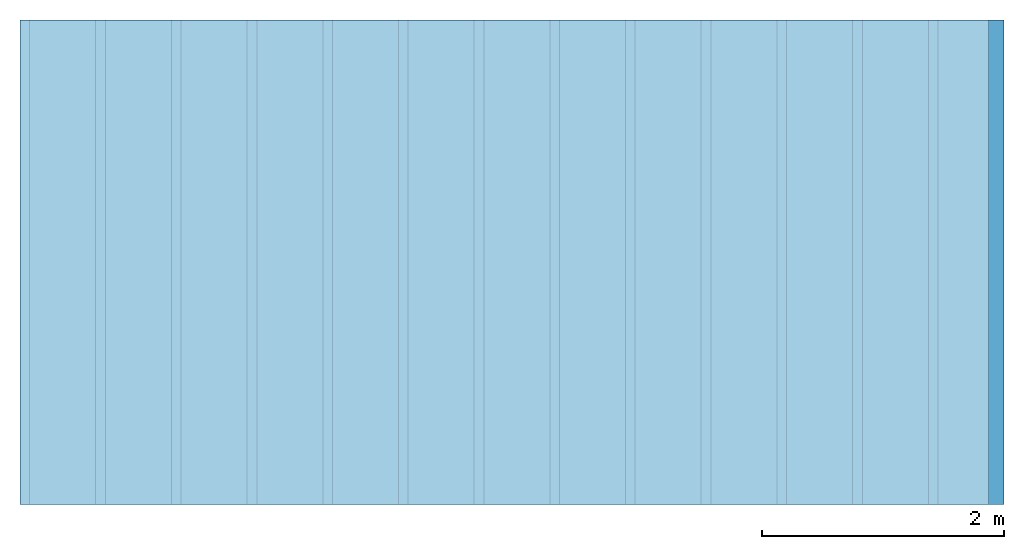
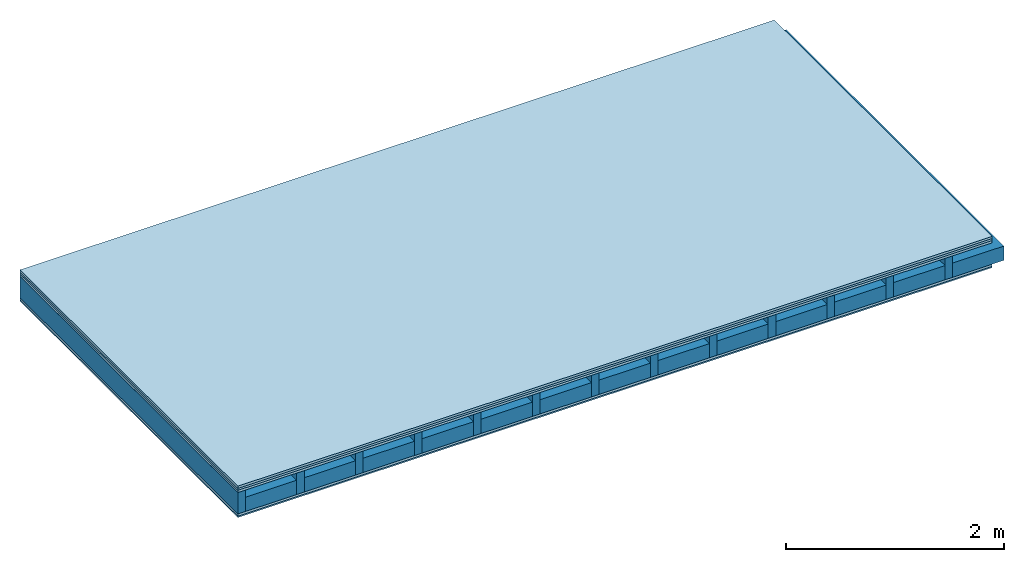
# One storey: 5 plates, 2 members, 1 element without a shape of its own.
"""IFC4 building model written with IfcOpenShell, lengths in metres."""

import ifcopenshell
import ifcopenshell.guid

model = None  # the IFC model being written
_history = None  # IfcOwnerHistory: only IFC2X3 demands one
_inside = {}  # id of a spatial element -> (the spatial element, [elements in it])
_under = {}  # id of a project, library or spatial element -> (it, [spatial elements below it])
_declared = {}  # id of a project -> (the project, [libraries it declares])
_typed = {}  # id of a type object -> (the type object, [elements of that type])
_made_of = {}  # id of a material, layer set ... -> (it, [elements and type objects made of it])


def new_model(schema):
    """Start an empty IFC model of exactly this schema.

    Asked for "IFC4X3", IfcOpenShell would pick the latest addendum, in which some entities
    have other attributes; the version numbers below select the first issue.
    IFC2X3 requires an IfcOwnerHistory on every rooted entity: one is made here for all.
    """
    global model, _history
    if schema == "IFC4X3":
        model = ifcopenshell.file(schema_version=(4, 3, 0, 0))
    else:
        model = ifcopenshell.file(schema=schema)
    _inside.clear()
    _under.clear()
    _declared.clear()
    _typed.clear()
    _made_of.clear()
    _history = None
    if model.schema == "IFC2X3":
        org = make("IfcOrganization", Name="unknown")
        user = make(
            "IfcPersonAndOrganization",
            ThePerson=make("IfcPerson", FamilyName="unknown"),
            TheOrganization=org,
        )
        app = make(
            "IfcApplication",
            ApplicationDeveloper=org,
            Version="unknown",
            ApplicationFullName="unknown",
            ApplicationIdentifier="unknown",
        )
        _history = make(
            "IfcOwnerHistory",
            OwningUser=user,
            OwningApplication=app,
            ChangeAction="ADDED",
            CreationDate=0,
        )
    return model


def make(cls, **values):
    """One entity of the class cls with the attributes given. An attribute that is None is left unset."""
    return model.create_entity(
        cls, **{name: value for name, value in values.items() if value is not None}
    )


def rooted(cls, **values):
    """An entity with a GlobalId (a new one), such as an element, a storey or a relation."""
    return make(cls, GlobalId=ifcopenshell.guid.new(), OwnerHistory=_history, **values)


def si_unit(unit_type, name, prefix=None):
    """IfcSIUnit, for example si_unit("LENGTHUNIT", "METRE", prefix="MILLI")."""
    return make("IfcSIUnit", UnitType=unit_type, Prefix=prefix, Name=name)


def derived_unit(unit_type, elements):
    """IfcDerivedUnit: a product of units, each with its exponent."""
    return make(
        "IfcDerivedUnit",
        Elements=[
            make("IfcDerivedUnitElement", Unit=unit, Exponent=power)
            for unit, power in elements
        ],
        UnitType=unit_type,
    )


def assignment(units):
    """IfcUnitAssignment: the units of a project."""
    return None if units is None else make("IfcUnitAssignment", Units=units)


def point(xyz):
    """IfcCartesianPoint."""
    return None if xyz is None else make("IfcCartesianPoint", Coordinates=xyz)


def direction(xyz):
    """IfcDirection."""
    return None if xyz is None else make("IfcDirection", DirectionRatios=xyz)


def frame(location, z_axis=None, x_axis=None):
    """IfcAxis2Placement3D, a coordinate frame: its origin and axes. An axis left out is left unset."""
    return make(
        "IfcAxis2Placement3D",
        Location=point(location),
        Axis=direction(z_axis),
        RefDirection=direction(x_axis),
    )


def frame_2d(location, x_axis=None):
    """IfcAxis2Placement2D, a coordinate frame in the plane: its origin and x axis."""
    return make(
        "IfcAxis2Placement2D", Location=point(location), RefDirection=direction(x_axis)
    )


def origin():
    """The frame at (0, 0, 0) with its axes left unset."""
    return frame((0.0, 0.0, 0.0))


def origin_with_axes():
    """The frame at (0, 0, 0) with the z axis (0, 0, 1) and the x axis (1, 0, 0) written out."""
    return frame((0.0, 0.0, 0.0), z_axis=(0.0, 0.0, 1.0), x_axis=(1.0, 0.0, 0.0))


def place(relative_to, where):
    """IfcLocalPlacement: puts the frame where relative to a parent placement (None: the world)."""
    return make(
        "IfcLocalPlacement", PlacementRelTo=relative_to, RelativePlacement=where
    )


def context(
    kind, dimensions, precision=None, world=None, true_north=None, identifier=None
):
    """IfcGeometricRepresentationContext, for example the 3D "Model" context."""
    return make(
        "IfcGeometricRepresentationContext",
        ContextIdentifier=identifier,
        ContextType=kind,
        CoordinateSpaceDimension=dimensions,
        Precision=precision,
        WorldCoordinateSystem=world,
        TrueNorth=true_north,
    )


def project(units=None, contexts=None):
    """IfcProject with its units and contexts."""
    return rooted(
        "IfcProject",
        Name="project",
        RepresentationContexts=contexts,
        UnitsInContext=assignment(units),
    )


def spatial(cls, under=None, at=None, **own):
    """A site, building, storey or space (cls), placed at a placement, below another one or the project."""
    s = rooted(cls, ObjectPlacement=at, **own)
    if under is not None:
        _under.setdefault(under.id(), (under, []))[1].append(s)
    return s


def profile(cls, at=None, kind="AREA", **sizes):
    """A parametric profile (cls). Its sizes go by their IFC names, for example OverallWidth=200.0."""
    return make(cls, ProfileType=kind, Position=at, **sizes)


def rectangle(**sizes):
    """IfcRectangleProfileDef."""
    return profile("IfcRectangleProfileDef", **sizes)


def extrude(swept, where, along, depth):
    """IfcExtrudedAreaSolid: the profile swept, set in the frame where, extruded along a direction by depth."""
    return make(
        "IfcExtrudedAreaSolid",
        SweptArea=swept,
        Position=where,
        ExtrudedDirection=direction(along),
        Depth=depth,
    )


def shape(context_of_items, identifier, shape_type, items):
    """IfcShapeRepresentation: the items that make up one representation, for example the "Body"."""
    return make(
        "IfcShapeRepresentation",
        ContextOfItems=context_of_items,
        RepresentationIdentifier=identifier,
        RepresentationType=shape_type,
        Items=items,
    )


def material(Name=None, Category=None):
    """IfcMaterial."""
    return make("IfcMaterial", Name=Name, Category=Category)


def layer(
    of_material, thickness, ventilated=None, Name=None, Category=None, Priority=None
):
    """IfcMaterialLayer: one layer of a wall or slab, of a material (None: an air gap)."""
    return make(
        "IfcMaterialLayer",
        Material=of_material,
        LayerThickness=thickness,
        IsVentilated=ventilated,
        Name=Name,
        Category=Category,
        Priority=Priority,
    )


def layer_set(layers, Name=None):
    """IfcMaterialLayerSet."""
    return make("IfcMaterialLayerSet", MaterialLayers=layers, LayerSetName=Name)


def made_of(thing, what):
    """Note that an element or type object is made of a material, layer set ...; save() writes the relation."""
    if what is not None:
        _made_of.setdefault(what.id(), (what, []))[1].append(thing)
    return thing


def type_object(cls, material=None, **own):
    """A type object (cls), such as IfcWallType, which elements share."""
    return made_of(rooted(cls, **own), material)


def element(
    cls,
    number,
    at=None,
    inside=None,
    cuts=None,
    type_object=None,
    material=None,
    context=None,
    identifier="Body",
    shape_type=None,
    held_by="IfcProductDefinitionShape",
    body=None,
    shapes=None,
    **own,
):
    """One element of the class cls, such as IfcWall. Its Tag is "e" and its number.

    at: its placement. inside: the storey or other place that contains it. cuts: it is an
    opening in that element (IfcRelVoidsElement). A single representation is given by context,
    identifier, shape_type and body (its items); several are given by shapes. held_by: the class
    of the entity that holds the representations. save() writes the other relations.
    """
    e = rooted(cls, Tag="e%d" % number, ObjectPlacement=at, **own)
    if body is not None:
        shapes = [shape(context, identifier, shape_type, body)]
    if shapes is not None:
        e.Representation = make(held_by, Representations=shapes)
    if inside is not None:
        _inside.setdefault(inside.id(), (inside, []))[1].append(e)
    if cuts is not None:
        rooted(
            "IfcRelVoidsElement", RelatingBuildingElement=cuts, RelatedOpeningElement=e
        )
    if type_object is not None:
        _typed.setdefault(type_object.id(), (type_object, []))[1].append(e)
    return made_of(e, material)


def aggregate(whole, parts):
    """IfcRelAggregates: a whole, such as a stair, and the parts it consists of."""
    return rooted("IfcRelAggregates", RelatingObject=whole, RelatedObjects=parts)


def save(model, path):
    """Write the relations noted so far, then the file.

    IfcRelAggregates (storeys below a building ...), IfcRelContainedInSpatialStructure (elements
    in a storey), IfcRelDefinesByType, IfcRelAssociatesMaterial and IfcRelDeclares: one each for
    every whole, place, type object, material and project.
    """
    for whole, parts in _under.values():
        aggregate(whole, parts)
    for where, things in _inside.values():
        rooted(
            "IfcRelContainedInSpatialStructure",
            RelatedElements=things,
            RelatingStructure=where,
        )
    for kind, things in _typed.values():
        rooted("IfcRelDefinesByType", RelatedObjects=things, RelatingType=kind)
    for what, things in _made_of.values():
        rooted("IfcRelAssociatesMaterial", RelatedObjects=things, RelatingMaterial=what)
    for by, libraries in _declared.values():
        rooted("IfcRelDeclares", RelatingContext=by, RelatedDefinitions=libraries)
    model.write(path)


model = new_model("IFC4")

# Units and contexts
plan_context = context("Plan", 3, precision=1e-05, world=origin(), true_north=direction((0.0, 1.0)))
model_context = context("Model", 3, precision=1e-05, world=origin(), true_north=direction((0.0, 1.0)))
ifc_project = project(units=[si_unit("LENGTHUNIT", "METRE"), derived_unit("SOUNDPRESSUREUNIT", [(si_unit("PRESSUREUNIT", "PASCAL", prefix="MICRO"), 0)]), si_unit("ENERGYUNIT", "JOULE", prefix="MEGA"), si_unit("MASSUNIT", "GRAM", prefix="KILO"), derived_unit("THERMALTRANSMITTANCEUNIT", [(si_unit("POWERUNIT", "WATT"), 1), (si_unit("AREAUNIT", "SQUARE_METRE"), -1), (si_unit("THERMODYNAMICTEMPERATUREUNIT", "KELVIN"), -1)]), derived_unit("AREADENSITYUNIT", [(si_unit("MASSUNIT", "GRAM", prefix="KILO"), 1), (si_unit("AREAUNIT", "SQUARE_METRE"), -1)]), derived_unit("USERDEFINED", [(si_unit("ENERGYUNIT", "JOULE", prefix="MEGA"), 1), (si_unit("AREAUNIT", "SQUARE_METRE"), -1)])], contexts=[plan_context, model_context])

# Site, building, storey
site = spatial("IfcSite", under=ifc_project)
building_placement = place(None, origin())
building = spatial("IfcBuilding", under=site, at=building_placement)
storey_placement = place(building_placement, origin())
storey = spatial("IfcBuildingStorey", under=building, at=storey_placement)

# Slab, members, plates
ifc_material_1 = material(Name="Floor heating system Therm38 longitudinal", Category="03.007")
ifc_layer_1 = layer(ifc_material_1, 0.025, Name="On-material")
ifc_material_2 = material(Category="10.009")
ifc_layer_2 = layer(ifc_material_2, 0.022, Name="Impact sound insulation")
ifc_material_3 = material(Category="07.001")
ifc_layer_3 = layer(ifc_material_3, 0.025, Name="Sub-floor")
ifc_material_4 = material(Name="Rigid, of the art")
ifc_layer_4 = layer(ifc_material_4, 0.0, Name="Bond")
ifc_layer_5 = layer(None, 0.24, Name="Supporting structure")
ifc_layer_6 = layer(ifc_material_4, 0.0, Name="Bond")
ifc_layer_7 = layer(ifc_material_3, 0.025, Name="Lower layer 1")
ifc_material_5 = material(Category="03.007")
ifc_layer_8 = layer(ifc_material_5, 0.015, Name="Lower 2nd layer")
ifc_layer_set = layer_set([ifc_layer_1, ifc_layer_2, ifc_layer_3, ifc_layer_4, ifc_layer_5, ifc_layer_6, ifc_layer_7, ifc_layer_8])
slab_type = type_object("IfcSlabType", Name="A0459", PredefinedType="NOTDEFINED", material=ifc_layer_set)
slab_placement = place(None, frame((0.0, 0.0, 0.0), z_axis=(0.0, 0.0, -1.0), x_axis=(1.0, 0.0, 0.0)))
slab = element("IfcSlab", 1, at=slab_placement, inside=storey, type_object=slab_type, material=ifc_layer_set, Name="Slab #1")
ifc_material_6 = material()
member_1_placement = place(slab_placement, origin())
member_1 = element("IfcMember", 2, at=member_1_placement, material=ifc_material_6, Name="Supporting structure", context=plan_context, shape_type="SweptSolid", body=[
    extrude(rectangle(XDim=0.08, YDim=0.24, at=frame_2d((0.04, 0.12), x_axis=(1.0, 0.0))), frame((0.0, 4.0, 0.072), z_axis=(0.0, -1.0, 0.0), x_axis=(1.0, 0.0, 0.0)), (0.0, 0.0, 1.0), 4.0),
    extrude(rectangle(XDim=0.08, YDim=0.24, at=frame_2d((0.04, 0.12), x_axis=(1.0, 0.0))), frame((0.625, 4.0, 0.072), z_axis=(0.0, -1.0, 0.0), x_axis=(1.0, 0.0, 0.0)), (0.0, 0.0, 1.0), 4.0),
    extrude(rectangle(XDim=0.08, YDim=0.24, at=frame_2d((0.04, 0.12), x_axis=(1.0, 0.0))), frame((1.25, 4.0, 0.072), z_axis=(0.0, -1.0, 0.0), x_axis=(1.0, 0.0, 0.0)), (0.0, 0.0, 1.0), 4.0),
    extrude(rectangle(XDim=0.08, YDim=0.24, at=frame_2d((0.04, 0.12), x_axis=(1.0, 0.0))), frame((1.875, 4.0, 0.072), z_axis=(0.0, -1.0, 0.0), x_axis=(1.0, 0.0, 0.0)), (0.0, 0.0, 1.0), 4.0),
    extrude(rectangle(XDim=0.08, YDim=0.24, at=frame_2d((0.04, 0.12), x_axis=(1.0, 0.0))), frame((2.5, 4.0, 0.072), z_axis=(0.0, -1.0, 0.0), x_axis=(1.0, 0.0, 0.0)), (0.0, 0.0, 1.0), 4.0),
    extrude(rectangle(XDim=0.08, YDim=0.24, at=frame_2d((0.04, 0.12), x_axis=(1.0, 0.0))), frame((3.125, 4.0, 0.072), z_axis=(0.0, -1.0, 0.0), x_axis=(1.0, 0.0, 0.0)), (0.0, 0.0, 1.0), 4.0),
    extrude(rectangle(XDim=0.08, YDim=0.24, at=frame_2d((0.04, 0.12), x_axis=(1.0, 0.0))), frame((3.75, 4.0, 0.072), z_axis=(0.0, -1.0, 0.0), x_axis=(1.0, 0.0, 0.0)), (0.0, 0.0, 1.0), 4.0),
    extrude(rectangle(XDim=0.08, YDim=0.24, at=frame_2d((0.04, 0.12), x_axis=(1.0, 0.0))), frame((4.375, 4.0, 0.072), z_axis=(0.0, -1.0, 0.0), x_axis=(1.0, 0.0, 0.0)), (0.0, 0.0, 1.0), 4.0),
    extrude(rectangle(XDim=0.08, YDim=0.24, at=frame_2d((0.04, 0.12), x_axis=(1.0, 0.0))), frame((5.0, 4.0, 0.072), z_axis=(0.0, -1.0, 0.0), x_axis=(1.0, 0.0, 0.0)), (0.0, 0.0, 1.0), 4.0),
    extrude(rectangle(XDim=0.08, YDim=0.24, at=frame_2d((0.04, 0.12), x_axis=(1.0, 0.0))), frame((5.625, 4.0, 0.072), z_axis=(0.0, -1.0, 0.0), x_axis=(1.0, 0.0, 0.0)), (0.0, 0.0, 1.0), 4.0),
    extrude(rectangle(XDim=0.08, YDim=0.24, at=frame_2d((0.04, 0.12), x_axis=(1.0, 0.0))), frame((6.25, 4.0, 0.072), z_axis=(0.0, -1.0, 0.0), x_axis=(1.0, 0.0, 0.0)), (0.0, 0.0, 1.0), 4.0),
    extrude(rectangle(XDim=0.08, YDim=0.24, at=frame_2d((0.04, 0.12), x_axis=(1.0, 0.0))), frame((6.875, 4.0, 0.072), z_axis=(0.0, -1.0, 0.0), x_axis=(1.0, 0.0, 0.0)), (0.0, 0.0, 1.0), 4.0),
    extrude(rectangle(XDim=0.08, YDim=0.24, at=frame_2d((0.04, 0.12), x_axis=(1.0, 0.0))), frame((7.5, 4.0, 0.072), z_axis=(0.0, -1.0, 0.0), x_axis=(1.0, 0.0, 0.0)), (0.0, 0.0, 1.0), 4.0),
])
ifc_material_7 = material()
member_2_placement = place(slab_placement, origin())
member_2 = element("IfcMember", 3, at=member_2_placement, material=ifc_material_7, Name="in supporting structure", context=plan_context, shape_type="SweptSolid", body=[
    extrude(rectangle(XDim=0.545, YDim=0.16, at=frame_2d((0.2725, 0.08), x_axis=(1.0, 0.0))), frame((0.08, 4.0, 0.152), z_axis=(0.0, -1.0, 0.0), x_axis=(1.0, 0.0, 0.0)), (0.0, 0.0, 1.0), 4.0),
    extrude(rectangle(XDim=0.545, YDim=0.16, at=frame_2d((0.2725, 0.08), x_axis=(1.0, 0.0))), frame((0.705, 4.0, 0.152), z_axis=(0.0, -1.0, 0.0), x_axis=(1.0, 0.0, 0.0)), (0.0, 0.0, 1.0), 4.0),
    extrude(rectangle(XDim=0.545, YDim=0.16, at=frame_2d((0.2725, 0.08), x_axis=(1.0, 0.0))), frame((1.33, 4.0, 0.152), z_axis=(0.0, -1.0, 0.0), x_axis=(1.0, 0.0, 0.0)), (0.0, 0.0, 1.0), 4.0),
    extrude(rectangle(XDim=0.545, YDim=0.16, at=frame_2d((0.2725, 0.08), x_axis=(1.0, 0.0))), frame((1.955, 4.0, 0.152), z_axis=(0.0, -1.0, 0.0), x_axis=(1.0, 0.0, 0.0)), (0.0, 0.0, 1.0), 4.0),
    extrude(rectangle(XDim=0.545, YDim=0.16, at=frame_2d((0.2725, 0.08), x_axis=(1.0, 0.0))), frame((2.58, 4.0, 0.152), z_axis=(0.0, -1.0, 0.0), x_axis=(1.0, 0.0, 0.0)), (0.0, 0.0, 1.0), 4.0),
    extrude(rectangle(XDim=0.545, YDim=0.16, at=frame_2d((0.2725, 0.08), x_axis=(1.0, 0.0))), frame((3.205, 4.0, 0.152), z_axis=(0.0, -1.0, 0.0), x_axis=(1.0, 0.0, 0.0)), (0.0, 0.0, 1.0), 4.0),
    extrude(rectangle(XDim=0.545, YDim=0.16, at=frame_2d((0.2725, 0.08), x_axis=(1.0, 0.0))), frame((3.83, 4.0, 0.152), z_axis=(0.0, -1.0, 0.0), x_axis=(1.0, 0.0, 0.0)), (0.0, 0.0, 1.0), 4.0),
    extrude(rectangle(XDim=0.545, YDim=0.16, at=frame_2d((0.2725, 0.08), x_axis=(1.0, 0.0))), frame((4.455, 4.0, 0.152), z_axis=(0.0, -1.0, 0.0), x_axis=(1.0, 0.0, 0.0)), (0.0, 0.0, 1.0), 4.0),
    extrude(rectangle(XDim=0.545, YDim=0.16, at=frame_2d((0.2725, 0.08), x_axis=(1.0, 0.0))), frame((5.08, 4.0, 0.152), z_axis=(0.0, -1.0, 0.0), x_axis=(1.0, 0.0, 0.0)), (0.0, 0.0, 1.0), 4.0),
    extrude(rectangle(XDim=0.545, YDim=0.16, at=frame_2d((0.2725, 0.08), x_axis=(1.0, 0.0))), frame((5.705, 4.0, 0.152), z_axis=(0.0, -1.0, 0.0), x_axis=(1.0, 0.0, 0.0)), (0.0, 0.0, 1.0), 4.0),
    extrude(rectangle(XDim=0.545, YDim=0.16, at=frame_2d((0.2725, 0.08), x_axis=(1.0, 0.0))), frame((6.33, 4.0, 0.152), z_axis=(0.0, -1.0, 0.0), x_axis=(1.0, 0.0, 0.0)), (0.0, 0.0, 1.0), 4.0),
    extrude(rectangle(XDim=0.545, YDim=0.16, at=frame_2d((0.2725, 0.08), x_axis=(1.0, 0.0))), frame((6.955, 4.0, 0.152), z_axis=(0.0, -1.0, 0.0), x_axis=(1.0, 0.0, 0.0)), (0.0, 0.0, 1.0), 4.0),
    extrude(rectangle(XDim=0.545, YDim=0.16, at=frame_2d((0.2725, 0.08), x_axis=(1.0, 0.0))), frame((7.58, 4.0, 0.152), z_axis=(0.0, -1.0, 0.0), x_axis=(1.0, 0.0, 0.0)), (0.0, 0.0, 1.0), 4.0),
])
plate_1_placement = place(slab_placement, origin())
plate_1 = element("IfcPlate", 4, at=plate_1_placement, material=ifc_material_1, Name="On-material", context=plan_context, shape_type="SweptSolid", body=[
    extrude(rectangle(XDim=8.0, YDim=4.0, at=frame_2d((4.0, 2.0), x_axis=(1.0, 0.0))), origin_with_axes(), (0.0, 0.0, 1.0), 0.025),
])
plate_2_placement = place(slab_placement, origin())
plate_2 = element("IfcPlate", 5, at=plate_2_placement, material=ifc_material_2, Name="Impact sound insulation", context=plan_context, shape_type="SweptSolid", body=[
    extrude(rectangle(XDim=8.0, YDim=4.0, at=frame_2d((4.0, 2.0), x_axis=(1.0, 0.0))), frame((0.0, 0.0, 0.025), z_axis=(0.0, 0.0, 1.0), x_axis=(1.0, 0.0, 0.0)), (0.0, 0.0, 1.0), 0.022),
])
plate_3_placement = place(slab_placement, origin())
plate_3 = element("IfcPlate", 6, at=plate_3_placement, material=ifc_material_3, Name="Sub-floor", context=plan_context, shape_type="SweptSolid", body=[
    extrude(rectangle(XDim=8.0, YDim=4.0, at=frame_2d((4.0, 2.0), x_axis=(1.0, 0.0))), frame((0.0, 0.0, 0.047), z_axis=(0.0, 0.0, 1.0), x_axis=(1.0, 0.0, 0.0)), (0.0, 0.0, 1.0), 0.025),
])
plate_4_placement = place(slab_placement, origin())
plate_4 = element("IfcPlate", 7, at=plate_4_placement, material=ifc_material_3, Name="Lower layer 1", context=plan_context, shape_type="SweptSolid", body=[
    extrude(rectangle(XDim=8.0, YDim=4.0, at=frame_2d((4.0, 2.0), x_axis=(1.0, 0.0))), frame((0.0, 0.0, 0.312), z_axis=(0.0, 0.0, 1.0), x_axis=(1.0, 0.0, 0.0)), (0.0, 0.0, 1.0), 0.025),
])
plate_5_placement = place(slab_placement, origin())
plate_5 = element("IfcPlate", 8, at=plate_5_placement, material=ifc_material_5, Name="Lower 2nd layer", context=plan_context, shape_type="SweptSolid", body=[
    extrude(rectangle(XDim=8.0, YDim=4.0, at=frame_2d((4.0, 2.0), x_axis=(1.0, 0.0))), frame((0.0, 0.0, 0.337), z_axis=(0.0, 0.0, 1.0), x_axis=(1.0, 0.0, 0.0)), (0.0, 0.0, 1.0), 0.015),
])
aggregate(slab, [plate_1, plate_2, plate_3, member_1, member_2, plate_4, plate_5])

save(model, "model.ifc")
